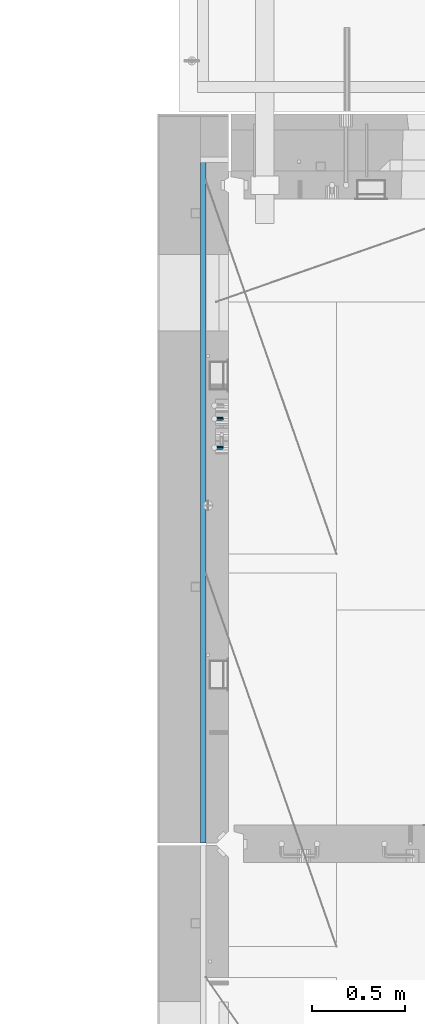
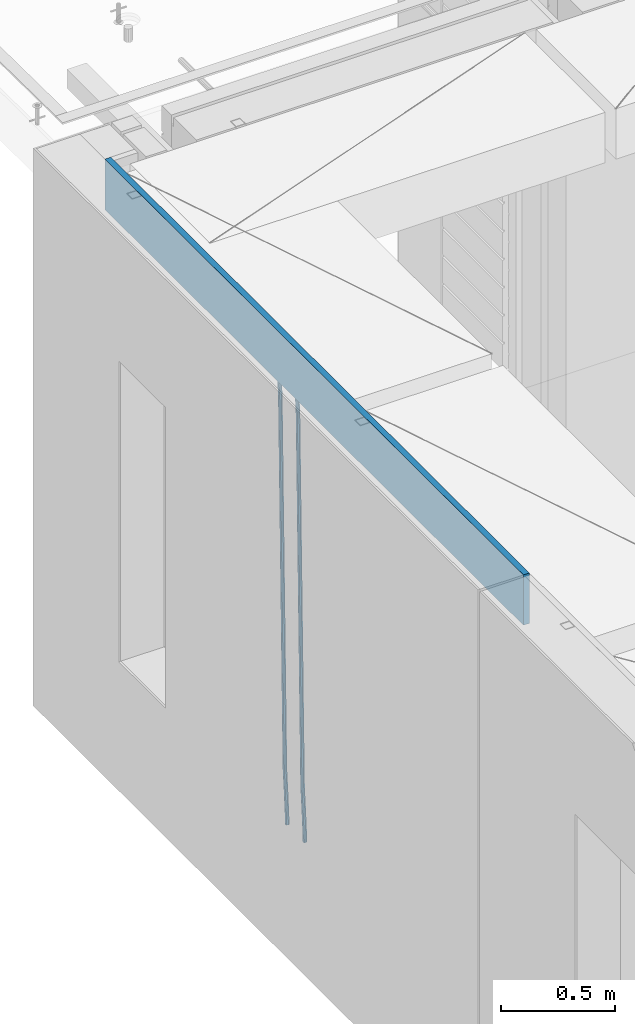
# One storey, part 112 of 352: 3 beams, 1 element without a shape of its own.
"""IFC2X3 building model written with IfcOpenShell, lengths in millimetres."""

import ifcopenshell
import ifcopenshell.guid

model = None  # the IFC model being written
_history = None  # IfcOwnerHistory: only IFC2X3 demands one
_inside = {}  # id of a spatial element -> (the spatial element, [elements in it])
_under = {}  # id of a project, library or spatial element -> (it, [spatial elements below it])
_declared = {}  # id of a project -> (the project, [libraries it declares])
_typed = {}  # id of a type object -> (the type object, [elements of that type])
_made_of = {}  # id of a material, layer set ... -> (it, [elements and type objects made of it])


def new_model(schema):
    """Start an empty IFC model of exactly this schema.

    Asked for "IFC4X3", IfcOpenShell would pick the latest addendum, in which some entities
    have other attributes; the version numbers below select the first issue.
    IFC2X3 requires an IfcOwnerHistory on every rooted entity: one is made here for all.
    """
    global model, _history
    if schema == "IFC4X3":
        model = ifcopenshell.file(schema_version=(4, 3, 0, 0))
    else:
        model = ifcopenshell.file(schema=schema)
    _inside.clear()
    _under.clear()
    _declared.clear()
    _typed.clear()
    _made_of.clear()
    _history = None
    if model.schema == "IFC2X3":
        org = make("IfcOrganization", Name="unknown")
        user = make(
            "IfcPersonAndOrganization",
            ThePerson=make("IfcPerson", FamilyName="unknown"),
            TheOrganization=org,
        )
        app = make(
            "IfcApplication",
            ApplicationDeveloper=org,
            Version="unknown",
            ApplicationFullName="unknown",
            ApplicationIdentifier="unknown",
        )
        _history = make(
            "IfcOwnerHistory",
            OwningUser=user,
            OwningApplication=app,
            ChangeAction="ADDED",
            CreationDate=0,
        )
    return model


def make(cls, **values):
    """One entity of the class cls with the attributes given. An attribute that is None is left unset."""
    return model.create_entity(
        cls, **{name: value for name, value in values.items() if value is not None}
    )


def rooted(cls, **values):
    """An entity with a GlobalId (a new one), such as an element, a storey or a relation."""
    return make(cls, GlobalId=ifcopenshell.guid.new(), OwnerHistory=_history, **values)


def si_unit(unit_type, name, prefix=None):
    """IfcSIUnit, for example si_unit("LENGTHUNIT", "METRE", prefix="MILLI")."""
    return make("IfcSIUnit", UnitType=unit_type, Prefix=prefix, Name=name)


def assignment(units):
    """IfcUnitAssignment: the units of a project."""
    return None if units is None else make("IfcUnitAssignment", Units=units)


def point(xyz):
    """IfcCartesianPoint."""
    return None if xyz is None else make("IfcCartesianPoint", Coordinates=xyz)


def direction(xyz):
    """IfcDirection."""
    return None if xyz is None else make("IfcDirection", DirectionRatios=xyz)


def frame(location, z_axis=None, x_axis=None):
    """IfcAxis2Placement3D, a coordinate frame: its origin and axes. An axis left out is left unset."""
    return make(
        "IfcAxis2Placement3D",
        Location=point(location),
        Axis=direction(z_axis),
        RefDirection=direction(x_axis),
    )


def origin_with_axes():
    """The frame at (0, 0, 0) with the z axis (0, 0, 1) and the x axis (1, 0, 0) written out."""
    return frame((0.0, 0.0, 0.0), z_axis=(0.0, 0.0, 1.0), x_axis=(1.0, 0.0, 0.0))


def place(relative_to, where):
    """IfcLocalPlacement: puts the frame where relative to a parent placement (None: the world)."""
    return make(
        "IfcLocalPlacement", PlacementRelTo=relative_to, RelativePlacement=where
    )


def context(
    kind, dimensions, precision=None, world=None, true_north=None, identifier=None
):
    """IfcGeometricRepresentationContext, for example the 3D "Model" context."""
    return make(
        "IfcGeometricRepresentationContext",
        ContextIdentifier=identifier,
        ContextType=kind,
        CoordinateSpaceDimension=dimensions,
        Precision=precision,
        WorldCoordinateSystem=world,
        TrueNorth=true_north,
    )


def subcontext(parent, identifier, kind, view, scale=None):
    """IfcGeometricRepresentationSubContext, for example "Body" below "Model"."""
    return make(
        "IfcGeometricRepresentationSubContext",
        ContextIdentifier=identifier,
        ContextType=kind,
        ParentContext=parent,
        TargetScale=scale,
        TargetView=view,
    )


def project(units=None, contexts=None):
    """IfcProject with its units and contexts."""
    return rooted(
        "IfcProject",
        Name="project",
        RepresentationContexts=contexts,
        UnitsInContext=assignment(units),
    )


def spatial(cls, under=None, at=None, **own):
    """A site, building, storey or space (cls), placed at a placement, below another one or the project."""
    s = rooted(cls, ObjectPlacement=at, **own)
    if under is not None:
        _under.setdefault(under.id(), (under, []))[1].append(s)
    return s


def faces_of(points, faces, orient=None, outer=None):
    """IfcFace entities. A face is a list of loops; a loop is a list of indices into points, from 0.

    orient and outer hold one flag for each loop. By default every Orientation is true, the
    first loop of a face is its IfcFaceOuterBound and the others are IfcFaceBound.
    """
    made = []
    for i, loops in enumerate(faces):
        bounds = []
        for j, loop in enumerate(loops):
            is_outer = j == 0 if outer is None else outer[i][j]
            bounds.append(
                make(
                    "IfcFaceOuterBound" if is_outer else "IfcFaceBound",
                    Bound=make("IfcPolyLoop", Polygon=[points[k] for k in loop]),
                    Orientation=True if orient is None else orient[i][j],
                )
            )
        made.append(make("IfcFace", Bounds=bounds))
    return made


def faceted_brep(points, faces, orient=None, outer=None, voids=None):
    """IfcFacetedBrep: a solid bounded by flat faces; with voids (closed shells), ...WithVoids."""
    shared = [point(p) for p in points]
    hull = make("IfcClosedShell", CfsFaces=faces_of(shared, faces, orient, outer))
    if voids is None:
        return make("IfcFacetedBrep", Outer=hull)
    return make(
        "IfcFacetedBrepWithVoids",
        Outer=hull,
        Voids=[
            make(cls, CfsFaces=faces_of(shared, fs, o, b)) for cls, fs, o, b in voids
        ],
    )


def shape(context_of_items, identifier, shape_type, items):
    """IfcShapeRepresentation: the items that make up one representation, for example the "Body"."""
    return make(
        "IfcShapeRepresentation",
        ContextOfItems=context_of_items,
        RepresentationIdentifier=identifier,
        RepresentationType=shape_type,
        Items=items,
    )


def material(Name=None, Category=None):
    """IfcMaterial."""
    return make("IfcMaterial", Name=Name, Category=Category)


def made_of(thing, what):
    """Note that an element or type object is made of a material, layer set ...; save() writes the relation."""
    if what is not None:
        _made_of.setdefault(what.id(), (what, []))[1].append(thing)
    return thing


def type_object(cls, material=None, **own):
    """A type object (cls), such as IfcWallType, which elements share."""
    return made_of(rooted(cls, **own), material)


def element(
    cls,
    number,
    at=None,
    inside=None,
    cuts=None,
    type_object=None,
    material=None,
    context=None,
    identifier="Body",
    shape_type=None,
    held_by="IfcProductDefinitionShape",
    body=None,
    shapes=None,
    **own,
):
    """One element of the class cls, such as IfcWall. Its Tag is "e" and its number.

    at: its placement. inside: the storey or other place that contains it. cuts: it is an
    opening in that element (IfcRelVoidsElement). A single representation is given by context,
    identifier, shape_type and body (its items); several are given by shapes. held_by: the class
    of the entity that holds the representations. save() writes the other relations.
    """
    e = rooted(cls, Tag="e%d" % number, ObjectPlacement=at, **own)
    if body is not None:
        shapes = [shape(context, identifier, shape_type, body)]
    if shapes is not None:
        e.Representation = make(held_by, Representations=shapes)
    if inside is not None:
        _inside.setdefault(inside.id(), (inside, []))[1].append(e)
    if cuts is not None:
        rooted(
            "IfcRelVoidsElement", RelatingBuildingElement=cuts, RelatedOpeningElement=e
        )
    if type_object is not None:
        _typed.setdefault(type_object.id(), (type_object, []))[1].append(e)
    return made_of(e, material)


def aggregate(whole, parts):
    """IfcRelAggregates: a whole, such as a stair, and the parts it consists of."""
    return rooted("IfcRelAggregates", RelatingObject=whole, RelatedObjects=parts)


def save(model, path):
    """Write the relations noted so far, then the file.

    IfcRelAggregates (storeys below a building ...), IfcRelContainedInSpatialStructure (elements
    in a storey), IfcRelDefinesByType, IfcRelAssociatesMaterial and IfcRelDeclares: one each for
    every whole, place, type object, material and project.
    """
    for whole, parts in _under.values():
        aggregate(whole, parts)
    for where, things in _inside.values():
        rooted(
            "IfcRelContainedInSpatialStructure",
            RelatedElements=things,
            RelatingStructure=where,
        )
    for kind, things in _typed.values():
        rooted("IfcRelDefinesByType", RelatedObjects=things, RelatingType=kind)
    for what, things in _made_of.values():
        rooted("IfcRelAssociatesMaterial", RelatedObjects=things, RelatingMaterial=what)
    for by, libraries in _declared.values():
        rooted("IfcRelDeclares", RelatingContext=by, RelatedDefinitions=libraries)
    model.write(path)


model = new_model("IFC2X3")

# Units and contexts
model_context = context("Model", 3, precision=1e-05, world=origin_with_axes())
body_context = subcontext(model_context, "Body", "Model", "MODEL_VIEW")
ifc_project = project(units=[si_unit("LENGTHUNIT", "METRE", prefix="MILLI"), si_unit("AREAUNIT", "SQUARE_METRE"), si_unit("VOLUMEUNIT", "CUBIC_METRE"), si_unit("MASSUNIT", "GRAM", prefix="KILO"), si_unit("TIMEUNIT", "SECOND"), si_unit("PLANEANGLEUNIT", "RADIAN"), si_unit("SOLIDANGLEUNIT", "STERADIAN"), si_unit("THERMODYNAMICTEMPERATUREUNIT", "DEGREE_CELSIUS"), si_unit("LUMINOUSINTENSITYUNIT", "LUMEN")], contexts=[model_context])

# Site, building, storey
site_placement = place(None, origin_with_axes())
site = spatial("IfcSite", under=ifc_project, at=site_placement, CompositionType="ELEMENT")
building_placement = place(site_placement, origin_with_axes())
building = spatial("IfcBuilding", under=site, at=building_placement, CompositionType="ELEMENT")
storey_placement = place(building_placement, origin_with_axes())
storey = spatial("IfcBuildingStorey", under=building, at=storey_placement, Name="6", CompositionType="ELEMENT", Elevation=0.0)

# Assembly, beams
assembly_placement = place(storey_placement, origin_with_axes())
assembly = element("IfcElementAssembly", 1, at=assembly_placement, inside=storey, AssemblyPlace="NOTDEFINED", PredefinedType="REINFORCEMENT_UNIT")
ifc_material_1 = material()
beam_type_1 = type_object("IfcBeamType", Name="D20", PredefinedType="NOTDEFINED")
beam_1_placement = place(assembly_placement, frame((7965.00000455602, 19100.0000000039, 96990.0), z_axis=(-0.999642804636942, -0.000205726999925762, -0.0267249099902983), x_axis=(-0.0267249099948371, 4.30000201934385e-08, 0.999642825806181)))
beam_1 = element("IfcBeam", 2, at=beam_1_placement, type_object=beam_type_1, material=ifc_material_1, Name="JM20", ObjectType="D20", context=body_context, shape_type="Brep", body=[
    faceted_brep([(0.0, -10.0, 0.0), (-4.19531716033816e-08, -7.07106781186667, -7.07106781187031), (60.4266690400545, -7.0710677960451, -7.07106780570757), (60.4266690441291, -9.99999998418934, 6.15546014159918e-09), (0.0, 0.0, -10.0), (60.426669036824, 1.58106558956206e-08, -9.99999999384454), (4.196772351861e-08, 7.07106781186303, -7.07106781186667), (60.4266690363438, 7.07106782768096, -7.07106780570757), (0.0, 10.0, 0.0), (60.4266690388904, 10.0000000158179, 6.15182216279209e-09), (4.196772351861e-08, 7.07106781185939, 7.07106781185939), (60.4266690429649, 7.07106782768096, 7.07106781802577), (0.0, 0.0, 10.0), (60.4266690461809, 1.58179318532348e-08, 10.0000000061555), (-4.19531716033816e-08, -7.07106781187031, 7.07106781185939), (60.4266690466611, -7.07106779605238, 7.07106781802213), (61.0378400410118, -7.07106779588503, -7.07106780564936), (60.991799419251, -9.99999998403655, 6.21366780251265e-09), (61.0569027789461, 1.5985278878361e-08, -9.99999999378269), (61.0378209396877, 7.07106782784831, -7.07106780564936), (60.9917724058905, 10.0000000159635, 6.21366780251265e-09), (60.9457317841297, 7.07106782781193, 7.0710678180767), (60.9266690461809, 1.59488990902901e-08, 10.0000000062028), (60.9457508854539, -7.07106779591413, 7.0710678180767), (61.6489592143771, -7.07106614513759, -7.06310863441468), (61.5568818710308, -9.9999984576425, 0.00735959856683621), (61.6870830769039, 1.71821739058942e-06, -9.99179257185824), (61.6489210170112, 7.07106947854481, -7.06310888312146), (61.556827851804, 10.0000015422847, 0.00735924683976918), (61.4647505084577, 7.07106922979438, 7.07782747982128), (61.4266266459163, 1.36643211590126e-06, 10.0065114172685), (61.464788705809, -7.07106639389531, 7.07782772852806), (176.543135720174, -7.07075579406956, -5.56673531796696), (176.451058376813, -9.99968810657447, 1.50373291501455), (176.581259582701, 0.000312069292704109, -8.49541925541052), (176.543097522794, 7.07137982961285, -5.56673556667374), (176.451004357587, 10.00031189336, 1.50373256329476), (176.35892701424, 7.07137958085514, 8.57420079627263), (176.320803151699, 0.000311717507429421, 11.5028847337162), (176.358965211621, -7.07075604281999, 8.57420104497578), (177.098753836006, -7.07075429323595, -5.55949898843028), (176.98362511232, -9.99968666800123, 1.510669025065), (177.146421932586, 0.000313595905026887, -8.48805862247536), (177.098706077581, 7.07138133041735, -5.55949936166144), (176.983557571715, 10.0003133318824, 1.51066849724157), (176.868428848029, 7.07138095712435, 8.58083651073321), (176.820760751449, 0.000313067976094317, 11.5093961447819), (176.868476606425, -7.07075466652896, 8.58083688396073), (177.654312950661, -7.07075204110879, -5.54863964998367), (177.516135294456, -9.99968450931192, 1.52107783331303), (177.711524267797, 0.000315886711177882, -8.47701274570863), (177.654255632195, 7.07138358250813, -5.54864021007961), (177.516054233929, 10.0003154905207, 1.5210770412159), (177.377876577739, 7.0713830223176, 8.59079452451624), (177.320665260588, 0.000315094497636892, 11.5191676202448), (177.377933896176, -7.07075260129932, 8.59079508461218), (299.436796249574, -7.07025836271714, -3.1681962331204), (299.298618593355, -9.99919083092027, 3.90152125031091), (299.494007566798, 0.000809565110102994, -6.09656932889993), (299.436738931283, 7.07187726089978, -3.16819679320906), (299.298537533061, 10.0008091689197, 3.90152045822106), (299.160359876842, 7.07187670072017, 10.9712379416487), (299.103148559603, 0.000808772889286047, 13.8996110374392), (299.160417195119, -7.07025892290039, 10.9712385017483), (299.98743051647, -7.07025613056248, -3.15743315966392), (299.971788958996, -9.99918809853989, 3.91467979818117), (299.993912075952, 0.000811591617093654, -6.08679785393178), (299.987423933868, 7.07187949325817, -3.1574327280432), (299.971753863239, 10.0008119014747, 3.91467990454839), (299.95611230444, 7.07187992653053, 10.9867922621015), (299.949630744944, 0.000812204350950196, 13.9161569563694), (299.956118887014, -7.07025569729012, 10.9867918304735), (300.538107039494, -7.07025785017686, -3.16575821840888), (300.644985195438, -9.99919020432935, 3.90450175465594), (300.493854948218, 0.000810030429420294, -6.09435592770024), (300.538151196495, 7.071877773491, -3.16575855385963), (300.645047642858, 10.0008097955724, 3.90450128024895), (300.751925798773, 7.07187744142357, 10.9747612533101), (300.796177890064, 0.000809560813650023, 13.9033589625978), (300.751881641787, -7.07025818224065, 10.9747615887682), (2293.36490490142, -7.07648090940347, -33.2930642912361), (2293.47178305736, -10.0054132635523, -26.2228043181785), (2293.32065281013, -0.00541302880083094, -36.2216620005347), (2293.36494905842, 7.06565471425711, -33.2930646266868), (2293.47184550477, 9.99458673634581, -26.2228047925819), (2293.57872366071, 7.06565438219332, -19.1525448195243), (2293.62297575199, -0.00541349841296324, -16.2239471102366), (2293.57867950371, -7.0764812414709, -19.1525444840736), (2294.0658245362, -7.07648309818615, -33.3036607065333), (2294.05312277409, -10.0054150789219, -26.2315929392535), (2294.10928714235, -0.00541549149056664, -36.2335844756526), (2294.15805078732, 7.06565223761572, -33.3050546393533), (2294.18355038921, 9.99458451388637, -26.2335642579346), (2294.17084862708, 7.06565253314329, -19.1614964906439), (2294.12738602093, -0.00541507354500936, -16.2315727215355), (2294.07862237596, -7.07648280265857, -19.1601025578348), (2294.76670261032, -7.08562269121467, -33.294332712383), (2294.63442802057, -10.0129954178956, -26.2238563411993), (2294.89787471293, -0.0156988342423574, -36.2230891548279), (2294.95110548967, 7.05531064255774, -33.2944998654275), (2294.89521307347, 9.98530428734011, -26.2240927312887), (2294.76293848372, 7.0579315606592, -19.1536163601049), (2294.63176638114, -0.0119922963167483, -16.2248599176673), (2294.57853560438, -7.08300177311321, -19.1534492070678), (2316.52657204497, -7.36937582653991, -33.0047303660212), (2316.39429745522, -10.2967485532172, -25.9342539948302), (2316.65774414754, -0.299451969567599, -35.9334868084661), (2316.7109749243, 6.7715575072325, -33.0048975190657), (2316.65508250811, 9.70155115201487, -25.9344903849269), (2316.52280791836, 6.7741784253376, -18.8640140137468), (2316.39163581574, -0.295745431634714, -15.9352575713092), (2316.33840503903, -7.36675490843481, -18.863846860706), (2317.16202064224, -7.37766220584308, -32.9962731735213), (2317.05438744847, -10.3053562613532, -25.9254688497131), (2317.23607125619, -0.306993473008333, -35.925789846493), (2317.23316144495, 6.76474808850253, -32.9979477328052), (2317.15499573652, 9.6950321815566, -25.9278370341635), (2317.04736254275, 6.7673381260538, -18.8570327103698), (2316.97331192881, -0.303330606784584, -15.9275160373909), (2316.97622174003, -7.37507216829545, -18.8553581510787), (2317.79752306276, -7.37578610372293, -32.9880110666527), (2317.71453320107, -10.3033876998124, -25.9168792378296), (2317.81444760226, -0.305295583297266, -35.918287695793), (2317.75539265381, 6.76628640723357, -32.9911928173897), (2317.65495180529, 9.69652304524061, -25.9213789128698), (2317.5719619436, 6.76892144914746, -18.8502470840467), (2317.55503740412, -0.301569071270933, -15.9199704549137), (2317.61409235255, -7.3731510618054, -18.847065333317), (2417.8183084176, -7.07752398473531, -31.6906369377139), (2417.73531855589, -10.0051255808248, -24.6195051088798), (2417.83523295709, -0.007033464313281, -34.6209135668432), (2417.77617800863, 7.06454852621755, -31.6938186884508), (2417.67573716014, 9.99478516423187, -24.6240047839383), (2417.59274729842, 7.06718356813872, -17.5528729551006), (2417.57582275895, -0.00330695228694822, -14.6225963259749), (2417.6348777074, -7.07488894281778, -17.5496912043673)], [[[0, 1, 2, 3]], [[1, 4, 5, 2]], [[4, 6, 7, 5]], [[6, 8, 9, 7]], [[8, 10, 11, 9]], [[10, 12, 13, 11]], [[12, 14, 15, 13]], [[14, 0, 3, 15]], [[14, 12, 10, 8, 6, 4, 1, 0]], [[3, 2, 16, 17]], [[2, 5, 18, 16]], [[5, 7, 19, 18]], [[7, 9, 20, 19]], [[9, 11, 21, 20]], [[11, 13, 22, 21]], [[13, 15, 23, 22]], [[15, 3, 17, 23]], [[17, 16, 24, 25]], [[16, 18, 26, 24]], [[18, 19, 27, 26]], [[19, 20, 28, 27]], [[20, 21, 29, 28]], [[21, 22, 30, 29]], [[22, 23, 31, 30]], [[23, 17, 25, 31]], [[25, 24, 32, 33]], [[24, 26, 34, 32]], [[26, 27, 35, 34]], [[27, 28, 36, 35]], [[28, 29, 37, 36]], [[29, 30, 38, 37]], [[30, 31, 39, 38]], [[31, 25, 33, 39]], [[33, 32, 40, 41]], [[32, 34, 42, 40]], [[34, 35, 43, 42]], [[35, 36, 44, 43]], [[36, 37, 45, 44]], [[37, 38, 46, 45]], [[38, 39, 47, 46]], [[39, 33, 41, 47]], [[41, 40, 48, 49]], [[40, 42, 50, 48]], [[42, 43, 51, 50]], [[43, 44, 52, 51]], [[44, 45, 53, 52]], [[45, 46, 54, 53]], [[46, 47, 55, 54]], [[47, 41, 49, 55]], [[49, 48, 56, 57]], [[48, 50, 58, 56]], [[50, 51, 59, 58]], [[51, 52, 60, 59]], [[52, 53, 61, 60]], [[53, 54, 62, 61]], [[54, 55, 63, 62]], [[55, 49, 57, 63]], [[57, 56, 64, 65]], [[56, 58, 66, 64]], [[58, 59, 67, 66]], [[59, 60, 68, 67]], [[60, 61, 69, 68]], [[61, 62, 70, 69]], [[62, 63, 71, 70]], [[63, 57, 65, 71]], [[65, 64, 72, 73]], [[64, 66, 74, 72]], [[66, 67, 75, 74]], [[67, 68, 76, 75]], [[68, 69, 77, 76]], [[69, 70, 78, 77]], [[70, 71, 79, 78]], [[71, 65, 73, 79]], [[73, 72, 80, 81]], [[72, 74, 82, 80]], [[74, 75, 83, 82]], [[75, 76, 84, 83]], [[76, 77, 85, 84]], [[77, 78, 86, 85]], [[78, 79, 87, 86]], [[79, 73, 81, 87]], [[81, 80, 88, 89]], [[80, 82, 90, 88]], [[82, 83, 91, 90]], [[83, 84, 92, 91]], [[84, 85, 93, 92]], [[85, 86, 94, 93]], [[86, 87, 95, 94]], [[87, 81, 89, 95]], [[89, 88, 96, 97]], [[88, 90, 98, 96]], [[90, 91, 99, 98]], [[91, 92, 100, 99]], [[92, 93, 101, 100]], [[93, 94, 102, 101]], [[94, 95, 103, 102]], [[95, 89, 97, 103]], [[97, 96, 104, 105]], [[96, 98, 106, 104]], [[98, 99, 107, 106]], [[99, 100, 108, 107]], [[100, 101, 109, 108]], [[101, 102, 110, 109]], [[102, 103, 111, 110]], [[103, 97, 105, 111]], [[105, 104, 112, 113]], [[104, 106, 114, 112]], [[106, 107, 115, 114]], [[107, 108, 116, 115]], [[108, 109, 117, 116]], [[109, 110, 118, 117]], [[110, 111, 119, 118]], [[111, 105, 113, 119]], [[113, 112, 120, 121]], [[112, 114, 122, 120]], [[114, 115, 123, 122]], [[115, 116, 124, 123]], [[116, 117, 125, 124]], [[117, 118, 126, 125]], [[118, 119, 127, 126]], [[119, 113, 121, 127]], [[121, 120, 128, 129]], [[120, 122, 130, 128]], [[122, 123, 131, 130]], [[123, 124, 132, 131]], [[124, 125, 133, 132]], [[125, 126, 134, 133]], [[126, 127, 135, 134]], [[127, 121, 129, 135]], [[130, 131, 132, 133, 134, 135, 129, 128]]]),
])
beam_2_placement = place(assembly_placement, frame((7965.00000455602, 19255.0000000039, 96990.0), z_axis=(-0.999642804636942, -0.000205726999925762, -0.0267249099902983), x_axis=(-0.0267249099948371, 4.30000201934385e-08, 0.999642825806181)))
beam_2 = element("IfcBeam", 3, at=beam_2_placement, type_object=beam_type_1, material=ifc_material_1, Name="JM20", ObjectType="D20", context=body_context, shape_type="Brep", body=[
    faceted_brep([(0.0, -10.0, 0.0), (-4.19531716033816e-08, -7.07106781186667, -7.07106781187031), (60.4266690400545, -7.0710677960451, -7.07106780570757), (60.4266690441291, -9.99999998418934, 6.15546014159918e-09), (0.0, 0.0, -10.0), (60.426669036824, 1.58106558956206e-08, -9.99999999384454), (4.196772351861e-08, 7.07106781186303, -7.07106781186667), (60.4266690363438, 7.07106782768096, -7.07106780570757), (0.0, 10.0, 0.0), (60.4266690388904, 10.0000000158179, 6.15182216279209e-09), (4.196772351861e-08, 7.07106781185939, 7.07106781185939), (60.4266690429649, 7.07106782768096, 7.07106781802577), (0.0, 0.0, 10.0), (60.4266690461809, 1.58179318532348e-08, 10.0000000061555), (-4.19531716033816e-08, -7.07106781187031, 7.07106781185939), (60.4266690466611, -7.07106779605238, 7.07106781802213), (61.0378400410118, -7.07106779588503, -7.07106780564936), (60.991799419251, -9.99999998403655, 6.21366780251265e-09), (61.0569027789461, 1.5985278878361e-08, -9.99999999378269), (61.0378209396877, 7.07106782784831, -7.07106780564936), (60.9917724058905, 10.0000000159635, 6.21366780251265e-09), (60.9457317841297, 7.07106782781193, 7.0710678180767), (60.9266690461809, 1.59488990902901e-08, 10.0000000062028), (60.9457508854539, -7.07106779591413, 7.0710678180767), (61.6489592143771, -7.07106614513759, -7.06310863441468), (61.5568818710308, -9.9999984576425, 0.00735959856683621), (61.6870830769039, 1.71821739058942e-06, -9.99179257185824), (61.6489210170112, 7.07106947854481, -7.06310888312146), (61.556827851804, 10.0000015422847, 0.00735924683976918), (61.4647505084577, 7.07106922979438, 7.07782747982128), (61.4266266459163, 1.36643211590126e-06, 10.0065114172685), (61.464788705809, -7.07106639389531, 7.07782772852806), (176.543135720174, -7.07075579406956, -5.56673531796696), (176.451058376813, -9.99968810657447, 1.50373291501455), (176.581259582701, 0.000312069292704109, -8.49541925541052), (176.543097522794, 7.07137982961285, -5.56673556667374), (176.451004357587, 10.00031189336, 1.50373256329476), (176.35892701424, 7.07137958085514, 8.57420079627263), (176.320803151699, 0.000311717507429421, 11.5028847337162), (176.358965211621, -7.07075604281999, 8.57420104497578), (177.098753836006, -7.07075429323595, -5.55949898843028), (176.98362511232, -9.99968666800123, 1.510669025065), (177.146421932586, 0.000313595905026887, -8.48805862247536), (177.098706077581, 7.07138133041735, -5.55949936166144), (176.983557571715, 10.0003133318824, 1.51066849724157), (176.868428848029, 7.07138095712435, 8.58083651073321), (176.820760751449, 0.000313067976094317, 11.5093961447819), (176.868476606425, -7.07075466652896, 8.58083688396073), (177.654312950661, -7.07075204110879, -5.54863964998367), (177.516135294456, -9.99968450931192, 1.52107783331303), (177.711524267797, 0.000315886711177882, -8.47701274570863), (177.654255632195, 7.07138358250813, -5.54864021007961), (177.516054233929, 10.0003154905207, 1.5210770412159), (177.377876577739, 7.0713830223176, 8.59079452451624), (177.320665260588, 0.000315094497636892, 11.5191676202448), (177.377933896176, -7.07075260129932, 8.59079508461218), (299.436796249574, -7.07025836271714, -3.1681962331204), (299.298618593355, -9.99919083092027, 3.90152125031091), (299.494007566798, 0.000809565110102994, -6.09656932889993), (299.436738931283, 7.07187726089978, -3.16819679320906), (299.298537533061, 10.0008091689197, 3.90152045822106), (299.160359876842, 7.07187670072017, 10.9712379416487), (299.103148559603, 0.000808772889286047, 13.8996110374392), (299.160417195119, -7.07025892290039, 10.9712385017483), (299.98743051647, -7.07025613056248, -3.15743315966392), (299.971788958996, -9.99918809853989, 3.91467979818117), (299.993912075952, 0.000811591617093654, -6.08679785393178), (299.987423933868, 7.07187949325817, -3.1574327280432), (299.971753863239, 10.0008119014747, 3.91467990454839), (299.95611230444, 7.07187992653053, 10.9867922621015), (299.949630744944, 0.000812204350950196, 13.9161569563694), (299.956118887014, -7.07025569729012, 10.9867918304735), (300.538107039494, -7.07025785017686, -3.16575821840888), (300.644985195438, -9.99919020432935, 3.90450175465594), (300.493854948218, 0.000810030429420294, -6.09435592770024), (300.538151196495, 7.071877773491, -3.16575855385963), (300.645047642858, 10.0008097955724, 3.90450128024895), (300.751925798773, 7.07187744142357, 10.9747612533101), (300.796177890064, 0.000809560813650023, 13.9033589625978), (300.751881641787, -7.07025818224065, 10.9747615887682), (2293.36490490142, -7.07648090940347, -33.2930642912361), (2293.47178305736, -10.0054132635523, -26.2228043181785), (2293.32065281013, -0.00541302880083094, -36.2216620005347), (2293.36494905842, 7.06565471425711, -33.2930646266868), (2293.47184550477, 9.99458673634581, -26.2228047925819), (2293.57872366071, 7.06565438219332, -19.1525448195243), (2293.62297575199, -0.00541349841296324, -16.2239471102366), (2293.57867950371, -7.0764812414709, -19.1525444840736), (2294.0658245362, -7.07648309818615, -33.3036607065333), (2294.05312277409, -10.0054150789219, -26.2315929392535), (2294.10928714235, -0.00541549149056664, -36.2335844756526), (2294.15805078732, 7.06565223761572, -33.3050546393533), (2294.18355038921, 9.99458451388637, -26.2335642579346), (2294.17084862708, 7.06565253314329, -19.1614964906439), (2294.12738602093, -0.00541507354500936, -16.2315727215355), (2294.07862237596, -7.07648280265857, -19.1601025578348), (2294.76670261032, -7.08562269121467, -33.294332712383), (2294.63442802057, -10.0129954178956, -26.2238563411993), (2294.89787471293, -0.0156988342423574, -36.2230891548279), (2294.95110548967, 7.05531064255774, -33.2944998654275), (2294.89521307347, 9.98530428734011, -26.2240927312887), (2294.76293848372, 7.0579315606592, -19.1536163601049), (2294.63176638114, -0.0119922963167483, -16.2248599176673), (2294.57853560438, -7.08300177311321, -19.1534492070678), (2316.52657204497, -7.36937582653991, -33.0047303660212), (2316.39429745522, -10.2967485532172, -25.9342539948302), (2316.65774414754, -0.299451969567599, -35.9334868084661), (2316.7109749243, 6.7715575072325, -33.0048975190657), (2316.65508250811, 9.70155115201487, -25.9344903849269), (2316.52280791836, 6.7741784253376, -18.8640140137468), (2316.39163581574, -0.295745431634714, -15.9352575713092), (2316.33840503903, -7.36675490843481, -18.863846860706), (2317.16202064224, -7.37766220584308, -32.9962731735213), (2317.05438744847, -10.3053562613532, -25.9254688497131), (2317.23607125619, -0.306993473008333, -35.925789846493), (2317.23316144495, 6.76474808850253, -32.9979477328052), (2317.15499573652, 9.6950321815566, -25.9278370341635), (2317.04736254275, 6.7673381260538, -18.8570327103698), (2316.97331192881, -0.303330606784584, -15.9275160373909), (2316.97622174003, -7.37507216829545, -18.8553581510787), (2317.79752306276, -7.37578610372293, -32.9880110666527), (2317.71453320107, -10.3033876998124, -25.9168792378296), (2317.81444760226, -0.305295583297266, -35.918287695793), (2317.75539265381, 6.76628640723357, -32.9911928173897), (2317.65495180529, 9.69652304524061, -25.9213789128698), (2317.5719619436, 6.76892144914746, -18.8502470840467), (2317.55503740412, -0.301569071270933, -15.9199704549137), (2317.61409235255, -7.3731510618054, -18.847065333317), (2417.8183084176, -7.07752398473531, -31.6906369377139), (2417.73531855589, -10.0051255808248, -24.6195051088798), (2417.83523295709, -0.007033464313281, -34.6209135668432), (2417.77617800863, 7.06454852621755, -31.6938186884508), (2417.67573716014, 9.99478516423187, -24.6240047839383), (2417.59274729842, 7.06718356813872, -17.5528729551006), (2417.57582275895, -0.00330695228694822, -14.6225963259749), (2417.6348777074, -7.07488894281778, -17.5496912043673)], [[[0, 1, 2, 3]], [[1, 4, 5, 2]], [[4, 6, 7, 5]], [[6, 8, 9, 7]], [[8, 10, 11, 9]], [[10, 12, 13, 11]], [[12, 14, 15, 13]], [[14, 0, 3, 15]], [[14, 12, 10, 8, 6, 4, 1, 0]], [[3, 2, 16, 17]], [[2, 5, 18, 16]], [[5, 7, 19, 18]], [[7, 9, 20, 19]], [[9, 11, 21, 20]], [[11, 13, 22, 21]], [[13, 15, 23, 22]], [[15, 3, 17, 23]], [[17, 16, 24, 25]], [[16, 18, 26, 24]], [[18, 19, 27, 26]], [[19, 20, 28, 27]], [[20, 21, 29, 28]], [[21, 22, 30, 29]], [[22, 23, 31, 30]], [[23, 17, 25, 31]], [[25, 24, 32, 33]], [[24, 26, 34, 32]], [[26, 27, 35, 34]], [[27, 28, 36, 35]], [[28, 29, 37, 36]], [[29, 30, 38, 37]], [[30, 31, 39, 38]], [[31, 25, 33, 39]], [[33, 32, 40, 41]], [[32, 34, 42, 40]], [[34, 35, 43, 42]], [[35, 36, 44, 43]], [[36, 37, 45, 44]], [[37, 38, 46, 45]], [[38, 39, 47, 46]], [[39, 33, 41, 47]], [[41, 40, 48, 49]], [[40, 42, 50, 48]], [[42, 43, 51, 50]], [[43, 44, 52, 51]], [[44, 45, 53, 52]], [[45, 46, 54, 53]], [[46, 47, 55, 54]], [[47, 41, 49, 55]], [[49, 48, 56, 57]], [[48, 50, 58, 56]], [[50, 51, 59, 58]], [[51, 52, 60, 59]], [[52, 53, 61, 60]], [[53, 54, 62, 61]], [[54, 55, 63, 62]], [[55, 49, 57, 63]], [[57, 56, 64, 65]], [[56, 58, 66, 64]], [[58, 59, 67, 66]], [[59, 60, 68, 67]], [[60, 61, 69, 68]], [[61, 62, 70, 69]], [[62, 63, 71, 70]], [[63, 57, 65, 71]], [[65, 64, 72, 73]], [[64, 66, 74, 72]], [[66, 67, 75, 74]], [[67, 68, 76, 75]], [[68, 69, 77, 76]], [[69, 70, 78, 77]], [[70, 71, 79, 78]], [[71, 65, 73, 79]], [[73, 72, 80, 81]], [[72, 74, 82, 80]], [[74, 75, 83, 82]], [[75, 76, 84, 83]], [[76, 77, 85, 84]], [[77, 78, 86, 85]], [[78, 79, 87, 86]], [[79, 73, 81, 87]], [[81, 80, 88, 89]], [[80, 82, 90, 88]], [[82, 83, 91, 90]], [[83, 84, 92, 91]], [[84, 85, 93, 92]], [[85, 86, 94, 93]], [[86, 87, 95, 94]], [[87, 81, 89, 95]], [[89, 88, 96, 97]], [[88, 90, 98, 96]], [[90, 91, 99, 98]], [[91, 92, 100, 99]], [[92, 93, 101, 100]], [[93, 94, 102, 101]], [[94, 95, 103, 102]], [[95, 89, 97, 103]], [[97, 96, 104, 105]], [[96, 98, 106, 104]], [[98, 99, 107, 106]], [[99, 100, 108, 107]], [[100, 101, 109, 108]], [[101, 102, 110, 109]], [[102, 103, 111, 110]], [[103, 97, 105, 111]], [[105, 104, 112, 113]], [[104, 106, 114, 112]], [[106, 107, 115, 114]], [[107, 108, 116, 115]], [[108, 109, 117, 116]], [[109, 110, 118, 117]], [[110, 111, 119, 118]], [[111, 105, 113, 119]], [[113, 112, 120, 121]], [[112, 114, 122, 120]], [[114, 115, 123, 122]], [[115, 116, 124, 123]], [[116, 117, 125, 124]], [[117, 118, 126, 125]], [[118, 119, 127, 126]], [[119, 113, 121, 127]], [[121, 120, 128, 129]], [[120, 122, 130, 128]], [[122, 123, 131, 130]], [[123, 124, 132, 131]], [[124, 125, 133, 132]], [[125, 126, 134, 133]], [[126, 127, 135, 134]], [[127, 121, 129, 135]], [[130, 131, 132, 133, 134, 135, 129, 128]]]),
])
ifc_material_2 = material(Name="CONCRETE/C25/30")
beam_type_2 = type_object("IfcBeamType", Name="270X30", PredefinedType="NOTDEFINED")
beam_3_placement = place(assembly_placement, frame((7865.0, 20654.9951872276, 99605.0), z_axis=(0.0, 0.0, 1.0), x_axis=(0.0, -1.0, 0.0)))
beam_3 = element("IfcBeam", 4, at=beam_3_placement, type_object=beam_type_2, material=ifc_material_2, ObjectType="270X30", context=body_context, shape_type="Brep", body=[
    faceted_brep([(0.0, 15.0, -135.0), (0.0, 15.0, 135.0), (3669.99518722759, 15.0, 135.0), (3669.99518722759, 15.0, -135.0), (0.0, -15.0, 135.0), (3669.99518722759, -15.0, 135.0), (0.0, -15.0, -135.0), (3669.99518722759, -15.0, -135.0)], [[[0, 1, 2, 3]], [[1, 4, 5, 2]], [[4, 6, 7, 5]], [[6, 0, 3, 7]], [[5, 7, 3, 2]], [[6, 4, 1, 0]]]),
])
aggregate(assembly, [beam_1, beam_2, beam_3])

save(model, "model.ifc")
